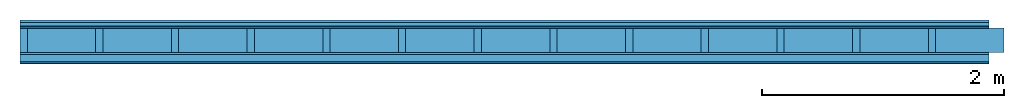
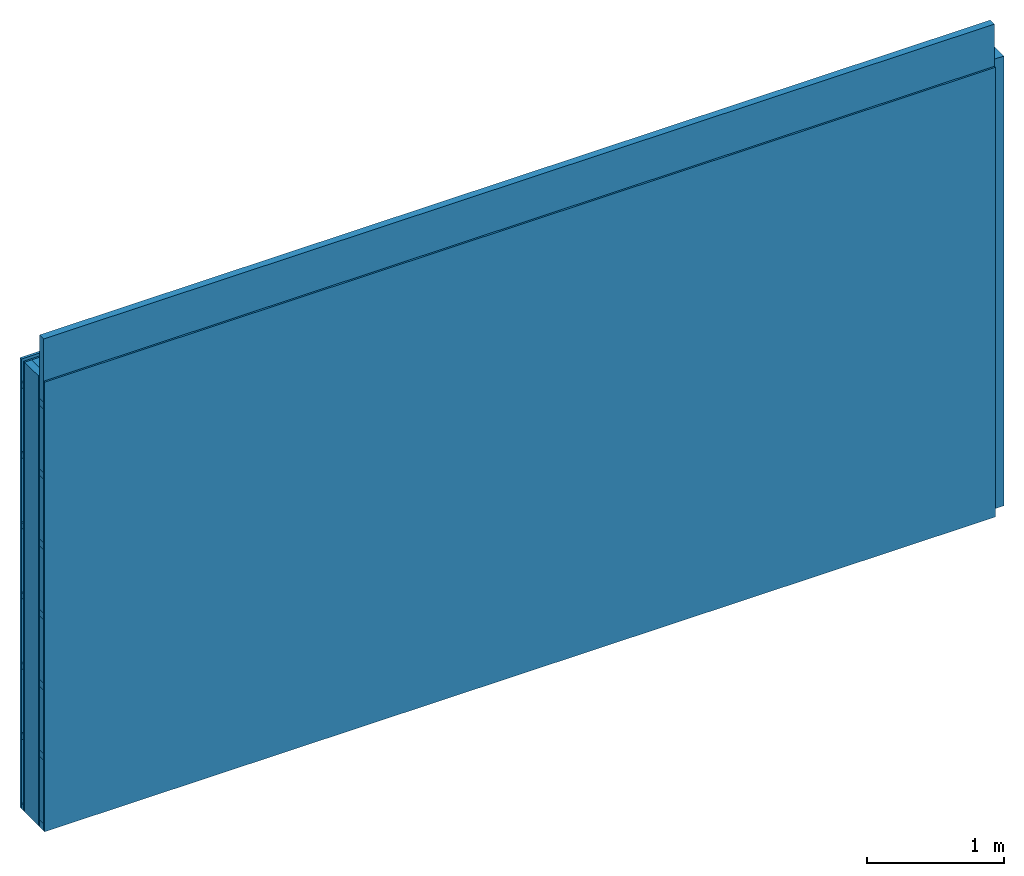
# One storey: 5 members, 4 plates, 1 element without a shape of its own.
"""IFC4 building model written with IfcOpenShell, lengths in metres."""

from ifc_helpers import new_model, si_unit, derived_unit, direction, frame, frame_2d, origin, origin_with_axes, place, context, project, spatial, rectangle, extrude, material, layer, layer_set, type_object, element, aggregate, save


model = new_model("IFC4")

# Units and contexts
plan_context = context("Plan", 3, precision=1e-05, world=origin(), true_north=direction((0.0, 1.0)))
model_context = context("Model", 3, precision=1e-05, world=origin(), true_north=direction((0.0, 1.0)))
ifc_project = project(units=[si_unit("LENGTHUNIT", "METRE"), derived_unit("SOUNDPRESSUREUNIT", [(si_unit("PRESSUREUNIT", "PASCAL", prefix="MICRO"), 0)]), si_unit("ENERGYUNIT", "JOULE", prefix="MEGA"), si_unit("MASSUNIT", "GRAM", prefix="KILO"), derived_unit("THERMALTRANSMITTANCEUNIT", [(si_unit("POWERUNIT", "WATT"), 1), (si_unit("AREAUNIT", "SQUARE_METRE"), -1), (si_unit("THERMODYNAMICTEMPERATUREUNIT", "KELVIN"), -1)]), derived_unit("AREADENSITYUNIT", [(si_unit("MASSUNIT", "GRAM", prefix="KILO"), 1), (si_unit("AREAUNIT", "SQUARE_METRE"), -1)]), derived_unit("USERDEFINED", [(si_unit("ENERGYUNIT", "JOULE", prefix="MEGA"), 1), (si_unit("AREAUNIT", "SQUARE_METRE"), -1)])], contexts=[plan_context, model_context])

# Site, building, storey
site = spatial("IfcSite", under=ifc_project)
building_placement = place(None, origin())
building = spatial("IfcBuilding", under=site, at=building_placement)
storey_placement = place(building_placement, origin())
storey = spatial("IfcBuildingStorey", under=building, at=storey_placement)

# Wall, members, plates
ifc_material_1 = material(Name="Wood cladding horizontal, closed")
ifc_layer_1 = layer(ifc_material_1, 0.022, Name="Cover 1st layer")
ifc_layer_2 = layer(None, 0.03, Name="Battens / profiles (ventilation)")
ifc_material_2 = material(Category="07.013")
ifc_layer_3 = layer(ifc_material_2, 0.015, Name="outside 1st layer")
ifc_material_3 = material(Name="of the art")
ifc_layer_4 = layer(ifc_material_3, 0.0, Name="Bond")
ifc_layer_5 = layer(None, 0.2, Name="Support")
ifc_layer_6 = layer(ifc_material_3, 0.0, Name="Bond")
ifc_layer_7 = layer(ifc_material_2, 0.018, Name="1st layer")
ifc_layer_8 = layer(None, 0.06, Name="Battens / profiles")
ifc_material_4 = material(Category="03.007")
ifc_layer_9 = layer(ifc_material_4, 0.015, Name="Covering 1st layer")
ifc_material_5 = material(Name="Glued joints")
ifc_layer_10 = layer(ifc_material_5, 0.0, Name="Surface")
ifc_layer_set = layer_set([ifc_layer_1, ifc_layer_2, ifc_layer_3, ifc_layer_4, ifc_layer_5, ifc_layer_6, ifc_layer_7, ifc_layer_8, ifc_layer_9, ifc_layer_10])
wall_type = type_object("IfcWallType", Name="D0260", PredefinedType="NOTDEFINED", material=ifc_layer_set)
wall_placement = place(None, frame((0.0, 0.0, 0.0), z_axis=(0.0, -1.0, 0.0), x_axis=(1.0, 0.0, 0.0)))
wall = element("IfcWall", 1, at=wall_placement, inside=storey, type_object=wall_type, material=ifc_layer_set, Name="Wall #1")
ifc_material_6 = material()
member_1_placement = place(wall_placement, origin())
member_1 = element("IfcMember", 2, at=member_1_placement, material=ifc_material_6, Name="Battens / profiles (ventilation)", context=plan_context, shape_type="SweptSolid", body=[
    extrude(rectangle(XDim=0.05, YDim=0.03, at=frame_2d((0.025, 0.015), x_axis=(1.0, 0.0))), frame((0.0, 0.0, 0.022), z_axis=(1.0, 0.0, 0.0), x_axis=(0.0, 1.0, 0.0)), (0.0, 0.0, 1.0), 8.0),
    extrude(rectangle(XDim=0.05, YDim=0.03, at=frame_2d((0.025, 0.015), x_axis=(1.0, 0.0))), frame((0.0, 0.625, 0.022), z_axis=(1.0, 0.0, 0.0), x_axis=(0.0, 1.0, 0.0)), (0.0, 0.0, 1.0), 8.0),
    extrude(rectangle(XDim=0.05, YDim=0.03, at=frame_2d((0.025, 0.015), x_axis=(1.0, 0.0))), frame((0.0, 1.25, 0.022), z_axis=(1.0, 0.0, 0.0), x_axis=(0.0, 1.0, 0.0)), (0.0, 0.0, 1.0), 8.0),
    extrude(rectangle(XDim=0.05, YDim=0.03, at=frame_2d((0.025, 0.015), x_axis=(1.0, 0.0))), frame((0.0, 1.875, 0.022), z_axis=(1.0, 0.0, 0.0), x_axis=(0.0, 1.0, 0.0)), (0.0, 0.0, 1.0), 8.0),
    extrude(rectangle(XDim=0.05, YDim=0.03, at=frame_2d((0.025, 0.015), x_axis=(1.0, 0.0))), frame((0.0, 2.5, 0.022), z_axis=(1.0, 0.0, 0.0), x_axis=(0.0, 1.0, 0.0)), (0.0, 0.0, 1.0), 8.0),
    extrude(rectangle(XDim=0.05, YDim=0.03, at=frame_2d((0.025, 0.015), x_axis=(1.0, 0.0))), frame((0.0, 3.125, 0.022), z_axis=(1.0, 0.0, 0.0), x_axis=(0.0, 1.0, 0.0)), (0.0, 0.0, 1.0), 8.0),
    extrude(rectangle(XDim=0.05, YDim=0.03, at=frame_2d((0.025, 0.015), x_axis=(1.0, 0.0))), frame((0.0, 3.75, 0.022), z_axis=(1.0, 0.0, 0.0), x_axis=(0.0, 1.0, 0.0)), (0.0, 0.0, 1.0), 8.0),
])
ifc_material_7 = material()
member_2_placement = place(wall_placement, origin())
member_2 = element("IfcMember", 3, at=member_2_placement, material=ifc_material_7, Name="Support", context=plan_context, shape_type="SweptSolid", body=[
    extrude(rectangle(XDim=0.06, YDim=0.2, at=frame_2d((0.03, 0.1), x_axis=(1.0, 0.0))), frame((0.0, 4.0, 0.067), z_axis=(0.0, -1.0, 0.0), x_axis=(1.0, 0.0, 0.0)), (0.0, 0.0, 1.0), 4.0),
    extrude(rectangle(XDim=0.06, YDim=0.2, at=frame_2d((0.03, 0.1), x_axis=(1.0, 0.0))), frame((0.625, 4.0, 0.067), z_axis=(0.0, -1.0, 0.0), x_axis=(1.0, 0.0, 0.0)), (0.0, 0.0, 1.0), 4.0),
    extrude(rectangle(XDim=0.06, YDim=0.2, at=frame_2d((0.03, 0.1), x_axis=(1.0, 0.0))), frame((1.25, 4.0, 0.067), z_axis=(0.0, -1.0, 0.0), x_axis=(1.0, 0.0, 0.0)), (0.0, 0.0, 1.0), 4.0),
    extrude(rectangle(XDim=0.06, YDim=0.2, at=frame_2d((0.03, 0.1), x_axis=(1.0, 0.0))), frame((1.875, 4.0, 0.067), z_axis=(0.0, -1.0, 0.0), x_axis=(1.0, 0.0, 0.0)), (0.0, 0.0, 1.0), 4.0),
    extrude(rectangle(XDim=0.06, YDim=0.2, at=frame_2d((0.03, 0.1), x_axis=(1.0, 0.0))), frame((2.5, 4.0, 0.067), z_axis=(0.0, -1.0, 0.0), x_axis=(1.0, 0.0, 0.0)), (0.0, 0.0, 1.0), 4.0),
    extrude(rectangle(XDim=0.06, YDim=0.2, at=frame_2d((0.03, 0.1), x_axis=(1.0, 0.0))), frame((3.125, 4.0, 0.067), z_axis=(0.0, -1.0, 0.0), x_axis=(1.0, 0.0, 0.0)), (0.0, 0.0, 1.0), 4.0),
    extrude(rectangle(XDim=0.06, YDim=0.2, at=frame_2d((0.03, 0.1), x_axis=(1.0, 0.0))), frame((3.75, 4.0, 0.067), z_axis=(0.0, -1.0, 0.0), x_axis=(1.0, 0.0, 0.0)), (0.0, 0.0, 1.0), 4.0),
    extrude(rectangle(XDim=0.06, YDim=0.2, at=frame_2d((0.03, 0.1), x_axis=(1.0, 0.0))), frame((4.375, 4.0, 0.067), z_axis=(0.0, -1.0, 0.0), x_axis=(1.0, 0.0, 0.0)), (0.0, 0.0, 1.0), 4.0),
    extrude(rectangle(XDim=0.06, YDim=0.2, at=frame_2d((0.03, 0.1), x_axis=(1.0, 0.0))), frame((5.0, 4.0, 0.067), z_axis=(0.0, -1.0, 0.0), x_axis=(1.0, 0.0, 0.0)), (0.0, 0.0, 1.0), 4.0),
    extrude(rectangle(XDim=0.06, YDim=0.2, at=frame_2d((0.03, 0.1), x_axis=(1.0, 0.0))), frame((5.625, 4.0, 0.067), z_axis=(0.0, -1.0, 0.0), x_axis=(1.0, 0.0, 0.0)), (0.0, 0.0, 1.0), 4.0),
    extrude(rectangle(XDim=0.06, YDim=0.2, at=frame_2d((0.03, 0.1), x_axis=(1.0, 0.0))), frame((6.25, 4.0, 0.067), z_axis=(0.0, -1.0, 0.0), x_axis=(1.0, 0.0, 0.0)), (0.0, 0.0, 1.0), 4.0),
    extrude(rectangle(XDim=0.06, YDim=0.2, at=frame_2d((0.03, 0.1), x_axis=(1.0, 0.0))), frame((6.875, 4.0, 0.067), z_axis=(0.0, -1.0, 0.0), x_axis=(1.0, 0.0, 0.0)), (0.0, 0.0, 1.0), 4.0),
    extrude(rectangle(XDim=0.06, YDim=0.2, at=frame_2d((0.03, 0.1), x_axis=(1.0, 0.0))), frame((7.5, 4.0, 0.067), z_axis=(0.0, -1.0, 0.0), x_axis=(1.0, 0.0, 0.0)), (0.0, 0.0, 1.0), 4.0),
])
ifc_material_8 = material()
member_3_placement = place(wall_placement, origin())
member_3 = element("IfcMember", 4, at=member_3_placement, material=ifc_material_8, Name="Cavity", context=plan_context, shape_type="SweptSolid", body=[
    extrude(rectangle(XDim=0.565, YDim=0.2, at=frame_2d((0.2825, 0.1), x_axis=(1.0, 0.0))), frame((0.06, 4.0, 0.067), z_axis=(0.0, -1.0, 0.0), x_axis=(1.0, 0.0, 0.0)), (0.0, 0.0, 1.0), 4.0),
    extrude(rectangle(XDim=0.565, YDim=0.2, at=frame_2d((0.2825, 0.1), x_axis=(1.0, 0.0))), frame((0.685, 4.0, 0.067), z_axis=(0.0, -1.0, 0.0), x_axis=(1.0, 0.0, 0.0)), (0.0, 0.0, 1.0), 4.0),
    extrude(rectangle(XDim=0.565, YDim=0.2, at=frame_2d((0.2825, 0.1), x_axis=(1.0, 0.0))), frame((1.31, 4.0, 0.067), z_axis=(0.0, -1.0, 0.0), x_axis=(1.0, 0.0, 0.0)), (0.0, 0.0, 1.0), 4.0),
    extrude(rectangle(XDim=0.565, YDim=0.2, at=frame_2d((0.2825, 0.1), x_axis=(1.0, 0.0))), frame((1.935, 4.0, 0.067), z_axis=(0.0, -1.0, 0.0), x_axis=(1.0, 0.0, 0.0)), (0.0, 0.0, 1.0), 4.0),
    extrude(rectangle(XDim=0.565, YDim=0.2, at=frame_2d((0.2825, 0.1), x_axis=(1.0, 0.0))), frame((2.56, 4.0, 0.067), z_axis=(0.0, -1.0, 0.0), x_axis=(1.0, 0.0, 0.0)), (0.0, 0.0, 1.0), 4.0),
    extrude(rectangle(XDim=0.565, YDim=0.2, at=frame_2d((0.2825, 0.1), x_axis=(1.0, 0.0))), frame((3.185, 4.0, 0.067), z_axis=(0.0, -1.0, 0.0), x_axis=(1.0, 0.0, 0.0)), (0.0, 0.0, 1.0), 4.0),
    extrude(rectangle(XDim=0.565, YDim=0.2, at=frame_2d((0.2825, 0.1), x_axis=(1.0, 0.0))), frame((3.81, 4.0, 0.067), z_axis=(0.0, -1.0, 0.0), x_axis=(1.0, 0.0, 0.0)), (0.0, 0.0, 1.0), 4.0),
    extrude(rectangle(XDim=0.565, YDim=0.2, at=frame_2d((0.2825, 0.1), x_axis=(1.0, 0.0))), frame((4.435, 4.0, 0.067), z_axis=(0.0, -1.0, 0.0), x_axis=(1.0, 0.0, 0.0)), (0.0, 0.0, 1.0), 4.0),
    extrude(rectangle(XDim=0.565, YDim=0.2, at=frame_2d((0.2825, 0.1), x_axis=(1.0, 0.0))), frame((5.06, 4.0, 0.067), z_axis=(0.0, -1.0, 0.0), x_axis=(1.0, 0.0, 0.0)), (0.0, 0.0, 1.0), 4.0),
    extrude(rectangle(XDim=0.565, YDim=0.2, at=frame_2d((0.2825, 0.1), x_axis=(1.0, 0.0))), frame((5.685, 4.0, 0.067), z_axis=(0.0, -1.0, 0.0), x_axis=(1.0, 0.0, 0.0)), (0.0, 0.0, 1.0), 4.0),
    extrude(rectangle(XDim=0.565, YDim=0.2, at=frame_2d((0.2825, 0.1), x_axis=(1.0, 0.0))), frame((6.31, 4.0, 0.067), z_axis=(0.0, -1.0, 0.0), x_axis=(1.0, 0.0, 0.0)), (0.0, 0.0, 1.0), 4.0),
    extrude(rectangle(XDim=0.565, YDim=0.2, at=frame_2d((0.2825, 0.1), x_axis=(1.0, 0.0))), frame((6.935, 4.0, 0.067), z_axis=(0.0, -1.0, 0.0), x_axis=(1.0, 0.0, 0.0)), (0.0, 0.0, 1.0), 4.0),
    extrude(rectangle(XDim=0.565, YDim=0.2, at=frame_2d((0.2825, 0.1), x_axis=(1.0, 0.0))), frame((7.56, 4.0, 0.067), z_axis=(0.0, -1.0, 0.0), x_axis=(1.0, 0.0, 0.0)), (0.0, 0.0, 1.0), 4.0),
])
ifc_material_9 = material()
member_4_placement = place(wall_placement, origin())
member_4 = element("IfcMember", 5, at=member_4_placement, material=ifc_material_9, Name="Battens / profiles", context=plan_context, shape_type="SweptSolid", body=[
    extrude(rectangle(XDim=0.06, YDim=0.06, at=frame_2d((0.03, 0.03), x_axis=(1.0, 0.0))), frame((0.0, 0.0, 0.285), z_axis=(1.0, 0.0, 0.0), x_axis=(0.0, 1.0, 0.0)), (0.0, 0.0, 1.0), 8.0),
    extrude(rectangle(XDim=0.06, YDim=0.06, at=frame_2d((0.03, 0.03), x_axis=(1.0, 0.0))), frame((0.0, 0.625, 0.285), z_axis=(1.0, 0.0, 0.0), x_axis=(0.0, 1.0, 0.0)), (0.0, 0.0, 1.0), 8.0),
    extrude(rectangle(XDim=0.06, YDim=0.06, at=frame_2d((0.03, 0.03), x_axis=(1.0, 0.0))), frame((0.0, 1.25, 0.285), z_axis=(1.0, 0.0, 0.0), x_axis=(0.0, 1.0, 0.0)), (0.0, 0.0, 1.0), 8.0),
    extrude(rectangle(XDim=0.06, YDim=0.06, at=frame_2d((0.03, 0.03), x_axis=(1.0, 0.0))), frame((0.0, 1.875, 0.285), z_axis=(1.0, 0.0, 0.0), x_axis=(0.0, 1.0, 0.0)), (0.0, 0.0, 1.0), 8.0),
    extrude(rectangle(XDim=0.06, YDim=0.06, at=frame_2d((0.03, 0.03), x_axis=(1.0, 0.0))), frame((0.0, 2.5, 0.285), z_axis=(1.0, 0.0, 0.0), x_axis=(0.0, 1.0, 0.0)), (0.0, 0.0, 1.0), 8.0),
    extrude(rectangle(XDim=0.06, YDim=0.06, at=frame_2d((0.03, 0.03), x_axis=(1.0, 0.0))), frame((0.0, 3.125, 0.285), z_axis=(1.0, 0.0, 0.0), x_axis=(0.0, 1.0, 0.0)), (0.0, 0.0, 1.0), 8.0),
    extrude(rectangle(XDim=0.06, YDim=0.06, at=frame_2d((0.03, 0.03), x_axis=(1.0, 0.0))), frame((0.0, 3.75, 0.285), z_axis=(1.0, 0.0, 0.0), x_axis=(0.0, 1.0, 0.0)), (0.0, 0.0, 1.0), 8.0),
])
member_5_placement = place(wall_placement, origin())
member_5 = element("IfcMember", 6, at=member_5_placement, material=ifc_material_8, Name="Cavity", context=plan_context, shape_type="SweptSolid", body=[
    extrude(rectangle(XDim=0.565, YDim=0.06, at=frame_2d((0.2825, 0.03), x_axis=(1.0, 0.0))), frame((0.0, 0.06, 0.285), z_axis=(1.0, 0.0, 0.0), x_axis=(0.0, 1.0, 0.0)), (0.0, 0.0, 1.0), 8.0),
    extrude(rectangle(XDim=0.565, YDim=0.06, at=frame_2d((0.2825, 0.03), x_axis=(1.0, 0.0))), frame((0.0, 0.685, 0.285), z_axis=(1.0, 0.0, 0.0), x_axis=(0.0, 1.0, 0.0)), (0.0, 0.0, 1.0), 8.0),
    extrude(rectangle(XDim=0.565, YDim=0.06, at=frame_2d((0.2825, 0.03), x_axis=(1.0, 0.0))), frame((0.0, 1.31, 0.285), z_axis=(1.0, 0.0, 0.0), x_axis=(0.0, 1.0, 0.0)), (0.0, 0.0, 1.0), 8.0),
    extrude(rectangle(XDim=0.565, YDim=0.06, at=frame_2d((0.2825, 0.03), x_axis=(1.0, 0.0))), frame((0.0, 1.935, 0.285), z_axis=(1.0, 0.0, 0.0), x_axis=(0.0, 1.0, 0.0)), (0.0, 0.0, 1.0), 8.0),
    extrude(rectangle(XDim=0.565, YDim=0.06, at=frame_2d((0.2825, 0.03), x_axis=(1.0, 0.0))), frame((0.0, 2.56, 0.285), z_axis=(1.0, 0.0, 0.0), x_axis=(0.0, 1.0, 0.0)), (0.0, 0.0, 1.0), 8.0),
    extrude(rectangle(XDim=0.565, YDim=0.06, at=frame_2d((0.2825, 0.03), x_axis=(1.0, 0.0))), frame((0.0, 3.185, 0.285), z_axis=(1.0, 0.0, 0.0), x_axis=(0.0, 1.0, 0.0)), (0.0, 0.0, 1.0), 8.0),
    extrude(rectangle(XDim=0.565, YDim=0.06, at=frame_2d((0.2825, 0.03), x_axis=(1.0, 0.0))), frame((0.0, 3.81, 0.285), z_axis=(1.0, 0.0, 0.0), x_axis=(0.0, 1.0, 0.0)), (0.0, 0.0, 1.0), 8.0),
])
plate_1_placement = place(wall_placement, origin())
plate_1 = element("IfcPlate", 7, at=plate_1_placement, material=ifc_material_1, Name="Cover 1st layer", context=plan_context, shape_type="SweptSolid", body=[
    extrude(rectangle(XDim=8.0, YDim=4.0, at=frame_2d((4.0, 2.0), x_axis=(1.0, 0.0))), origin_with_axes(), (0.0, 0.0, 1.0), 0.022),
])
plate_2_placement = place(wall_placement, origin())
plate_2 = element("IfcPlate", 8, at=plate_2_placement, material=ifc_material_2, Name="outside 1st layer", context=plan_context, shape_type="SweptSolid", body=[
    extrude(rectangle(XDim=8.0, YDim=4.0, at=frame_2d((4.0, 2.0), x_axis=(1.0, 0.0))), frame((0.0, 0.0, 0.052), z_axis=(0.0, 0.0, 1.0), x_axis=(1.0, 0.0, 0.0)), (0.0, 0.0, 1.0), 0.015),
])
plate_3_placement = place(wall_placement, origin())
plate_3 = element("IfcPlate", 9, at=plate_3_placement, material=ifc_material_2, Name="1st layer", context=plan_context, shape_type="SweptSolid", body=[
    extrude(rectangle(XDim=8.0, YDim=4.0, at=frame_2d((4.0, 2.0), x_axis=(1.0, 0.0))), frame((0.0, 0.0, 0.267), z_axis=(0.0, 0.0, 1.0), x_axis=(1.0, 0.0, 0.0)), (0.0, 0.0, 1.0), 0.018),
])
plate_4_placement = place(wall_placement, origin())
plate_4 = element("IfcPlate", 10, at=plate_4_placement, material=ifc_material_4, Name="Covering 1st layer", context=plan_context, shape_type="SweptSolid", body=[
    extrude(rectangle(XDim=8.0, YDim=4.0, at=frame_2d((4.0, 2.0), x_axis=(1.0, 0.0))), frame((0.0, 0.0, 0.345), z_axis=(0.0, 0.0, 1.0), x_axis=(1.0, 0.0, 0.0)), (0.0, 0.0, 1.0), 0.015),
])
aggregate(wall, [plate_1, member_1, plate_2, member_2, member_3, plate_3, member_4, member_5, plate_4])

save(model, "model.ifc")
